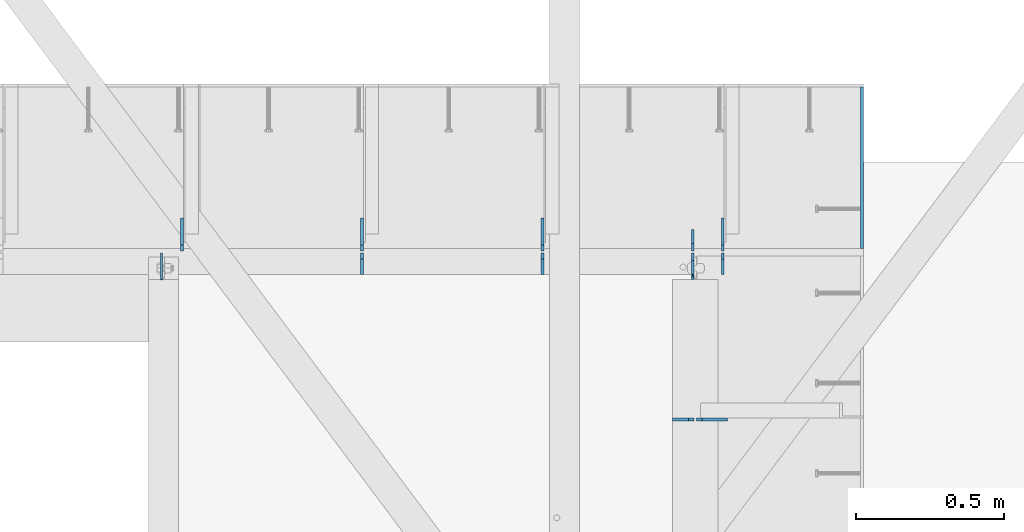
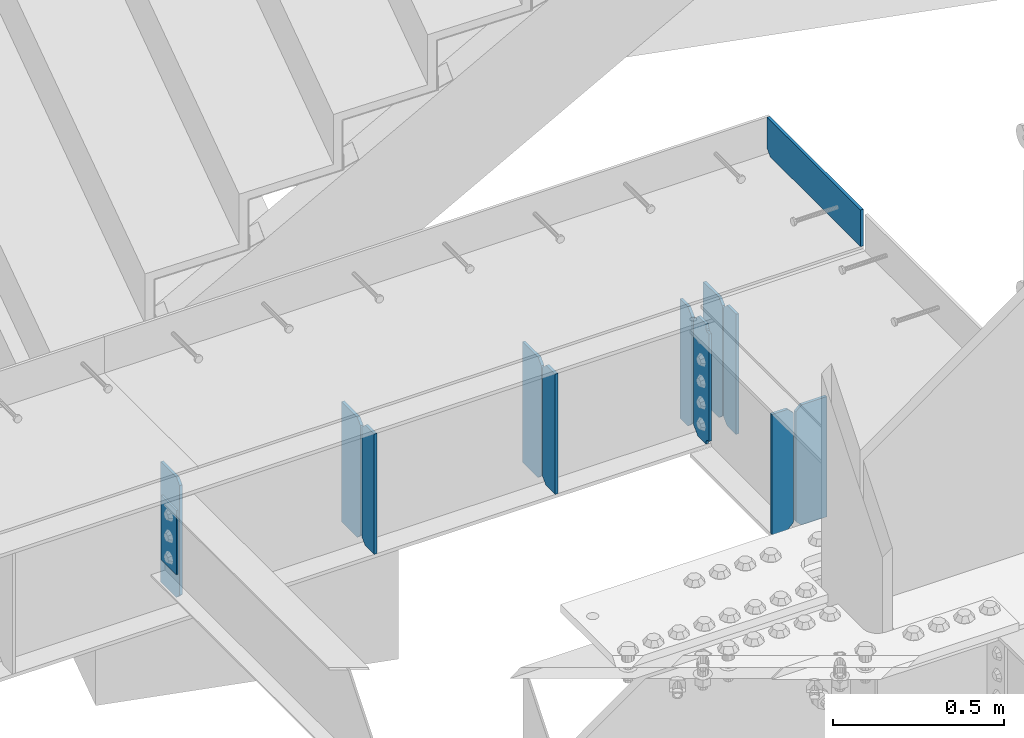
# One storey, part 1650 of 1763: 13 plates, 2 elements without a shape of their own.
"""IFC2X3 building model written with IfcOpenShell, lengths in millimetres."""

from ifc_helpers import new_model, si_unit, frame, origin_with_axes, place, context, subcontext, project, spatial, faceted_brep, material, type_object, element, aggregate, save


model = new_model("IFC2X3")

# Units and contexts
model_context = context("Model", 3, precision=1e-05, world=origin_with_axes())
body_context = subcontext(model_context, "Body", "Model", "MODEL_VIEW")
ifc_project = project(units=[si_unit("LENGTHUNIT", "METRE", prefix="MILLI"), si_unit("AREAUNIT", "SQUARE_METRE"), si_unit("VOLUMEUNIT", "CUBIC_METRE"), si_unit("MASSUNIT", "GRAM", prefix="KILO"), si_unit("TIMEUNIT", "SECOND"), si_unit("PLANEANGLEUNIT", "RADIAN"), si_unit("SOLIDANGLEUNIT", "STERADIAN"), si_unit("THERMODYNAMICTEMPERATUREUNIT", "DEGREE_CELSIUS"), si_unit("LUMINOUSINTENSITYUNIT", "LUMEN")], contexts=[model_context])

# Site, building, storey
site_placement = place(None, origin_with_axes())
site = spatial("IfcSite", under=ifc_project, at=site_placement, CompositionType="ELEMENT")
building_placement = place(site_placement, origin_with_axes())
building = spatial("IfcBuilding", under=site, at=building_placement, Name="Undefined", CompositionType="ELEMENT")
storey_placement = place(building_placement, origin_with_axes())
storey = spatial("IfcBuildingStorey", under=building, at=storey_placement, Name="Undefined", CompositionType="ELEMENT", Elevation=0.0)

# Assembly, plate
assembly_1_placement = place(storey_placement, origin_with_axes())
assembly_1 = element("IfcElementAssembly", 1, at=assembly_1_placement, inside=storey, Name="BEAM", AssemblyPlace="NOTDEFINED", PredefinedType="RIGID_FRAME")
ifc_material = material(Name="STEEL/A36")
plate_type_1 = type_object("IfcPlateType", PredefinedType="NOTDEFINED")
plate_1_placement = place(assembly_1_placement, frame((-34385.9151174483, 53657.5000095489, 5203.82498576935), z_axis=(-7.28999999410008e-07, 0.999999999970235, -7.68099774631993e-06), x_axis=(3.05799998314049e-06, 7.68099997558332e-06, 0.999999999965825)))
plate_1 = element("IfcPlate", 2, at=plate_1_placement, type_object=plate_type_1, material=ifc_material, Name="PLATE", context=body_context, shape_type="Brep", body=[
    faceted_brep([(0.0, -4.76249999999982, 0.0), (0.00404840682767826, -4.76249999999709, 527.049976349779), (0.00404840682494978, 4.76249999998254, 527.049976349794), (0.0, 4.76249999999982, 0.0), (19.054193971303, -4.76250000004075, 546.099832674743), (19.0541939713003, 4.76249999993161, 546.099832674765), (130.179183960079, -4.76250000030268, 546.098999024165), (130.179183960076, 4.76249999967695, 546.09899902418), (130.17500305171, -4.76250000028813, 3.63797880709171e-10), (130.175003051707, 4.7624999996915, 3.78349795937538e-10)], [[[0, 1, 2, 3]], [[1, 4, 5, 2]], [[4, 6, 7, 5]], [[6, 8, 9, 7]], [[8, 0, 3, 9]], [[5, 7, 9, 3, 2]], [[8, 6, 4, 1, 0]]]),
])

# Assembly, plates
assembly_2_placement = place(storey_placement, origin_with_axes())
assembly_2 = element("IfcElementAssembly", 3, at=assembly_2_placement, inside=storey, Name="BEAM", AssemblyPlace="NOTDEFINED", PredefinedType="RIGID_FRAME")
plate_type_2 = type_object("IfcPlateType", PredefinedType="NOTDEFINED")
plate_2_placement = place(assembly_2_placement, frame((-34841.0935236983, 53078.8562499995, 4752.975), z_axis=(0.0, 0.0, 1.0), x_axis=(-1.0, 0.0, 0.0)))
plate_2 = element("IfcPlate", 4, at=plate_2_placement, type_object=plate_type_2, material=ifc_material, Name="PLATE", context=body_context, shape_type="Brep", body=[
    faceted_brep([(0.0, -4.76249999999982, 0.0), (0.0, -4.76249999999709, 428.625), (0.0, 4.76249999999709, 428.625), (0.0, 4.76249999999982, 0.0), (85.7250022888184, -4.76249999999709, 428.625), (85.7250022888184, 4.76249999999709, 428.625), (104.775001525879, -4.76249999999709, 409.575000762939), (104.775001525879, 4.76249999999709, 409.575000762939), (104.775001525879, -4.76249999999709, 19.0499992370605), (104.775001525879, 4.76249999999709, 19.0499992370605), (85.7250022888184, -4.76249999999709, 0.0), (85.7250022888184, 4.76249999999709, 0.0)], [[[0, 1, 2, 3]], [[1, 4, 5, 2]], [[4, 6, 7, 5]], [[6, 8, 9, 7]], [[8, 10, 11, 9]], [[10, 0, 3, 11]], [[5, 7, 9, 11, 3, 2]], [[10, 8, 6, 4, 1, 0]]]),
])
plate_type_3 = type_object("IfcPlateType", PredefinedType="NOTDEFINED")
plate_3_placement = place(assembly_2_placement, frame((-34953.8060236984, 53078.8562499989, 4752.975), z_axis=(0.0, 0.0, 1.0), x_axis=(-1.0, 0.0, 0.0)))
plate_3 = element("IfcPlate", 5, at=plate_3_placement, type_object=plate_type_3, material=ifc_material, Name="PLATE", context=body_context, shape_type="Brep", body=[
    faceted_brep([(6.96272763889283e-08, -4.76249999999709, 19.0499992370605), (0.0, -4.76249999999709, 409.575000762939), (0.0, 4.76249999999709, 409.575000762939), (6.96454662829638e-08, 4.76249999999709, 19.0499992370605), (19.0499992370605, -4.76249999999709, 428.625), (19.0499992370605, 4.76249999999709, 428.625), (72.2312469482422, -4.76249999999709, 428.625), (72.2312469482422, 4.76249999999709, 428.625), (72.2312469482422, -4.76249999999709, 0.0), (72.2312469482422, 4.76249999999709, 0.0), (19.0499992370533, -4.76249999996799, -2.09183781407773e-11), (19.0499992370678, 4.76250000003347, -2.09183781407773e-11)], [[[0, 1, 2, 3]], [[1, 4, 5, 2]], [[4, 6, 7, 5]], [[6, 8, 9, 7]], [[8, 10, 11, 9]], [[10, 0, 3, 11]], [[5, 7, 9, 11, 3, 2]], [[10, 8, 6, 4, 1, 0]]]),
])
aggregate(assembly_2, [plate_2, plate_3])

# Plate
plate_4_placement = place(assembly_1_placement, frame((-34857.1669734054, 53568.6, 4752.975), z_axis=(0.0, 0.0, 1.0), x_axis=(0.0, 1.0, 0.0)))
plate_4 = element("IfcPlate", 6, at=plate_4_placement, type_object=plate_type_3, material=ifc_material, Name="PLATE", context=body_context, shape_type="Brep", body=[
    faceted_brep([(0.0, -4.76249999999982, 0.0), (0.0, -4.76249999999709, 428.625), (0.0, 4.76249999999709, 428.625), (0.0, 4.76249999999982, 0.0), (53.1812477111816, -4.76249999999709, 428.625), (53.1812477111816, 4.76249999999709, 428.625), (72.2312469482422, -4.76249999999709, 409.575000762939), (72.2312469482422, 4.76249999999709, 409.575000762939), (72.2312469482422, -4.76249999999709, 19.0499992370605), (72.2312469482422, 4.76249999999709, 19.0499992370605), (53.1812477111816, -4.76249999999709, 0.0), (53.1812477111816, 4.76249999999709, 0.0)], [[[0, 1, 2, 3]], [[1, 4, 5, 2]], [[4, 6, 7, 5]], [[6, 8, 9, 7]], [[8, 10, 11, 9]], [[10, 0, 3, 11]], [[5, 7, 9, 11, 3, 2]], [[10, 8, 6, 4, 1, 0]]]),
])

plate_5_placement = place(assembly_1_placement, frame((-35466.7669734054, 53568.6, 4752.975), z_axis=(0.0, 0.0, 1.0), x_axis=(0.0, 1.0, 0.0)))
plate_5 = element("IfcPlate", 7, at=plate_5_placement, type_object=plate_type_3, material=ifc_material, Name="PLATE", context=body_context, shape_type="Brep", body=[
    faceted_brep([(0.0, -4.76249999999982, 0.0), (0.0, -4.76249999999709, 428.625), (0.0, 4.76249999999709, 428.625), (0.0, 4.76249999999982, 0.0), (53.1812477111816, -4.76249999999709, 428.625), (53.1812477111816, 4.76249999999709, 428.625), (72.2312469482422, -4.76249999999709, 409.575000762939), (72.2312469482422, 4.76249999999709, 409.575000762939), (72.2312469482422, -4.76249999999709, 19.0499992370605), (72.2312469482422, 4.76249999999709, 19.0499992370605), (53.1812477111816, -4.76249999999709, 0.0), (53.1812477111816, 4.76249999999709, 0.0)], [[[0, 1, 2, 3]], [[1, 4, 5, 2]], [[4, 6, 7, 5]], [[6, 8, 9, 7]], [[8, 10, 11, 9]], [[10, 0, 3, 11]], [[5, 7, 9, 11, 3, 2]], [[10, 8, 6, 4, 1, 0]]]),
])

plate_6_placement = place(assembly_1_placement, frame((-36076.3669734054, 53568.6, 4752.975), z_axis=(0.0, 0.0, 1.0), x_axis=(0.0, 1.0, 0.0)))
plate_6 = element("IfcPlate", 8, at=plate_6_placement, type_object=plate_type_3, material=ifc_material, Name="PLATE", context=body_context, shape_type="Brep", body=[
    faceted_brep([(0.0, -4.76249999999982, 0.0), (0.0, -4.76249999999709, 428.625), (0.0, 4.76249999999709, 428.625), (0.0, 4.76249999999982, 0.0), (53.1812477111816, -4.76249999999709, 428.625), (53.1812477111816, 4.76249999999709, 428.625), (72.2312469482422, -4.76249999999709, 409.575000762939), (72.2312469482422, 4.76249999999709, 409.575000762939), (72.2312469482422, -4.76249999999709, 19.0499992370605), (72.2312469482422, 4.76249999999709, 19.0499992370605), (53.1812477111816, -4.76249999999709, 0.0), (53.1812477111816, 4.76249999999709, 0.0)], [[[0, 1, 2, 3]], [[1, 4, 5, 2]], [[4, 6, 7, 5]], [[6, 8, 9, 7]], [[8, 10, 11, 9]], [[10, 0, 3, 11]], [[5, 7, 9, 11, 3, 2]], [[10, 8, 6, 4, 1, 0]]]),
])

plate_7_placement = place(assembly_1_placement, frame((-34958.5690236144, 53648.76875, 4754.5625), z_axis=(0.0, 0.0, 1.0), x_axis=(0.0, 1.0, 0.0)))
plate_7 = element("IfcPlate", 9, at=plate_7_placement, type_object=plate_type_3, material=ifc_material, Name="PLATE", context=body_context, shape_type="Brep", body=[
    faceted_brep([(0.0, -4.76250000000073, 25.3999996185303), (0.0, -4.76249999999709, 400.050012588501), (0.0, 4.76249999999709, 400.050012588501), (0.0, 4.76250000000073, 25.3999996185303), (25.3999996185303, -4.76249999999709, 425.450012207031), (25.3999996185303, 4.76249999999709, 425.450012207031), (72.2312469482422, -4.76249999999709, 425.450012207031), (72.2312469482422, 4.76249999999709, 425.450012207031), (72.2312469482422, -4.76249999999709, 0.0), (72.2312469482422, 4.76249999999709, 0.0), (25.3999996185303, -4.76250000000073, 0.0), (25.3999996185303, 4.76250000000073, 0.0)], [[[0, 1, 2, 3]], [[1, 4, 5, 2]], [[4, 6, 7, 5]], [[6, 8, 9, 7]], [[8, 10, 11, 9]], [[10, 0, 3, 11]], [[5, 7, 9, 11, 3, 2]], [[10, 8, 6, 4, 1, 0]]]),
])

plate_type_4 = type_object("IfcPlateType", PredefinedType="NOTDEFINED")
plate_8_placement = place(assembly_1_placement, frame((-34857.1669734054, 53648.76875, 4752.975), z_axis=(0.0, 0.0, 1.0), x_axis=(0.0, 1.0, 0.0)))
plate_8 = element("IfcPlate", 10, at=plate_8_placement, type_object=plate_type_4, material=ifc_material, Name="PLATE", context=body_context, shape_type="Brep", body=[
    faceted_brep([(6.96272763889283e-08, -4.76249999999709, 19.0499992370605), (0.0, -4.76249999999709, 409.575000762939), (0.0, 4.76249999999709, 409.575000762939), (6.96454662829638e-08, 4.76249999999709, 19.0499992370605), (19.0499992370605, -4.76249999999709, 428.625), (19.0499992370605, 4.76249999999709, 428.625), (111.125, -4.76249999999709, 428.625), (111.125, 4.76249999999709, 428.625), (111.125, -4.76249999999709, 0.0), (111.125, 4.76249999999709, 0.0), (19.0499992370533, -4.76249999996799, -2.09183781407773e-11), (19.0499992370678, 4.76250000003347, -2.09183781407773e-11)], [[[0, 1, 2, 3]], [[1, 4, 5, 2]], [[4, 6, 7, 5]], [[6, 8, 9, 7]], [[8, 10, 11, 9]], [[10, 0, 3, 11]], [[5, 7, 9, 11, 3, 2]], [[10, 8, 6, 4, 1, 0]]]),
])

plate_9_placement = place(assembly_1_placement, frame((-35466.7669734054, 53648.76875, 4752.975), z_axis=(0.0, 0.0, 1.0), x_axis=(0.0, 1.0, 0.0)))
plate_9 = element("IfcPlate", 11, at=plate_9_placement, type_object=plate_type_4, material=ifc_material, Name="PLATE", context=body_context, shape_type="Brep", body=[
    faceted_brep([(6.96272763889283e-08, -4.76249999999709, 19.0499992370605), (0.0, -4.76249999999709, 409.575000762939), (0.0, 4.76249999999709, 409.575000762939), (6.96454662829638e-08, 4.76249999999709, 19.0499992370605), (19.0499992370605, -4.76249999999709, 428.625), (19.0499992370605, 4.76249999999709, 428.625), (111.125, -4.76249999999709, 428.625), (111.125, 4.76249999999709, 428.625), (111.125, -4.76249999999709, 0.0), (111.125, 4.76249999999709, 0.0), (19.0499992370533, -4.76249999996799, -2.09183781407773e-11), (19.0499992370678, 4.76250000003347, -2.09183781407773e-11)], [[[0, 1, 2, 3]], [[1, 4, 5, 2]], [[4, 6, 7, 5]], [[6, 8, 9, 7]], [[8, 10, 11, 9]], [[10, 0, 3, 11]], [[5, 7, 9, 11, 3, 2]], [[10, 8, 6, 4, 1, 0]]]),
])

plate_10_placement = place(assembly_1_placement, frame((-36076.3669734054, 53648.76875, 4752.975), z_axis=(0.0, 0.0, 1.0), x_axis=(0.0, 1.0, 0.0)))
plate_10 = element("IfcPlate", 12, at=plate_10_placement, type_object=plate_type_4, material=ifc_material, Name="PLATE", context=body_context, shape_type="Brep", body=[
    faceted_brep([(6.96272763889283e-08, -4.76249999999709, 19.0499992370605), (0.0, -4.76249999999709, 409.575000762939), (0.0, 4.76249999999709, 409.575000762939), (6.96454662829638e-08, 4.76249999999709, 19.0499992370605), (19.0499992370605, -4.76249999999709, 428.625), (19.0499992370605, 4.76249999999709, 428.625), (111.125, -4.76249999999709, 428.625), (111.125, 4.76249999999709, 428.625), (111.125, -4.76249999999709, 0.0), (111.125, 4.76249999999709, 0.0), (19.0499992370533, -4.76249999996799, -2.09183781407773e-11), (19.0499992370678, 4.76250000003347, -2.09183781407773e-11)], [[[0, 1, 2, 3]], [[1, 4, 5, 2]], [[4, 6, 7, 5]], [[6, 8, 9, 7]], [[8, 10, 11, 9]], [[10, 0, 3, 11]], [[5, 7, 9, 11, 3, 2]], [[10, 8, 6, 4, 1, 0]]]),
])

plate_11_placement = place(assembly_1_placement, frame((-36685.9669734054, 53648.76875, 4752.975), z_axis=(0.0, 0.0, 1.0), x_axis=(0.0, 1.0, 0.0)))
plate_11 = element("IfcPlate", 13, at=plate_11_placement, type_object=plate_type_4, material=ifc_material, Name="PLATE", context=body_context, shape_type="Brep", body=[
    faceted_brep([(6.96272763889283e-08, -4.76249999999709, 19.0499992370605), (0.0, -4.76249999999709, 409.575000762939), (0.0, 4.76249999999709, 409.575000762939), (6.96454662829638e-08, 4.76249999999709, 19.0499992370605), (19.0499992370605, -4.76249999999709, 428.625), (19.0499992370605, 4.76249999999709, 428.625), (111.125, -4.76249999999709, 428.625), (111.125, 4.76249999999709, 428.625), (111.125, -4.76249999999709, 0.0), (111.125, 4.76249999999709, 0.0), (19.0499992370533, -4.76249999996799, -2.09183781407773e-11), (19.0499992370678, 4.76250000003347, -2.09183781407773e-11)], [[[0, 1, 2, 3]], [[1, 4, 5, 2]], [[4, 6, 7, 5]], [[6, 8, 9, 7]], [[8, 10, 11, 9]], [[10, 0, 3, 11]], [[5, 7, 9, 11, 3, 2]], [[10, 8, 6, 4, 1, 0]]]),
])

plate_type_5 = type_object("IfcPlateType", PredefinedType="NOTDEFINED")
plate_12_placement = place(assembly_1_placement, frame((-34958.5690236144, 53640.83125, 4754.5625), z_axis=(0.0, 0.0, 1.0), x_axis=(0.0, -1.0, 0.0)))
plate_12 = element("IfcPlate", 14, at=plate_12_placement, type_object=plate_type_5, material=ifc_material, Name="PLATE", context=body_context, shape_type="Brep", body=[
    faceted_brep([(72.2312469482422, -4.76249999999709, 0.0), (72.2312469482422, 4.76249999999709, 0.0), (72.2312469482422, 4.76249999999709, 6.3499994277945), (72.2312469482422, -4.76249999999709, 6.3499994277945), (73.1979768708334, 4.76249999999709, 11.21007894584), (73.1979768708334, -4.76249999999709, 11.21007894584), (75.9509907713073, 4.76249999999709, 15.3302554139937), (75.9509907713073, -4.76249999999709, 15.3302554139937), (80.0711672394609, 4.76249999999709, 18.0832693144721), (80.0711672394609, -4.76249999999709, 18.0832693144721), (84.9312467575073, 4.76249999999709, 19.0499992370596), (84.9312467575073, -4.76249999999709, 19.0499992370596), (88.9000015258789, -4.76249999999709, 19.0499992370596), (88.9000015258789, 4.76249999999709, 19.0499992370596), (25.3999996185303, -4.76250000000073, 0.0), (0.0, -4.76250000000073, 25.3999996185303), (0.0, 4.76250000000073, 25.3999996185303), (25.3999996185303, 4.76250000000073, 0.0), (0.0, -4.76249999999709, 401.637506484985), (0.0, 4.76249999999709, 401.637506484985), (25.3999996185303, -4.76249999999709, 427.037506103516), (25.3999996185303, 4.76249999999709, 427.037506103516), (72.2312469482422, -4.76249999999709, 427.037506103516), (72.2312469482422, 4.76249999999709, 427.037506103516), (72.2312469482422, -4.76249999999709, 414.337499809265), (72.2312469482422, 4.76249999999709, 414.337499809265), (73.1979768708334, -4.76249999999709, 409.477420291219), (73.1979768708334, 4.76249999999709, 409.477420291219), (75.9509907713073, -4.76249999999709, 405.357243823066), (75.9509907713073, 4.76249999999709, 405.357243823066), (80.0711672394609, -4.76249999999709, 402.604229922587), (80.0711672394609, 4.76249999999709, 402.604229922587), (84.9312467575073, -4.76249999999709, 401.6375), (84.9312467575073, 4.76249999999709, 401.6375), (88.9000015258789, -4.76249999999709, 401.6375), (88.9000015258789, 4.76249999999709, 401.6375)], [[[0, 1, 2, 3]], [[3, 2, 4, 5]], [[5, 4, 6, 7]], [[7, 6, 8, 9]], [[9, 8, 10, 11]], [[12, 11, 10, 13]], [[14, 15, 16, 17]], [[15, 18, 19, 16]], [[18, 20, 21, 19]], [[21, 20, 22, 23]], [[22, 24, 25, 23]], [[26, 27, 25, 24]], [[28, 29, 27, 26]], [[30, 31, 29, 28]], [[32, 33, 31, 30]], [[34, 35, 33, 32]], [[35, 34, 12, 13]], [[8, 6, 4, 2, 1, 17, 16, 19, 21, 23, 25, 27, 29, 31, 33, 35, 13, 10]], [[0, 14, 17, 1]], [[34, 32, 30, 28, 26, 24, 22, 20, 18, 15, 14, 0, 3, 5, 7, 9, 11, 12]]]),
])

plate_type_6 = type_object("IfcPlateType", PredefinedType="NOTDEFINED")
plate_13_placement = place(assembly_1_placement, frame((-36754.758627365, 53640.83125, 5156.2), z_axis=(0.0, -1.0, 0.0), x_axis=(0.0, 0.0, -1.0)))
plate_13 = element("IfcPlate", 15, at=plate_13_placement, type_object=plate_type_6, material=ifc_material, Name="PLATE", context=body_context, shape_type="Brep", body=[
    faceted_brep([(1.81898940354586e-12, -3.17500000000291, 0.0), (0.0, -3.17499999999927, 88.9000015258789), (0.0, 3.17499999999927, 88.9000015258789), (-1.81898940354586e-12, 3.17499999997381, 0.0), (228.600006103516, -3.17499999999927, 88.9000015258789), (228.600006103516, 3.17499999999927, 88.9000015258789), (228.600006103516, -3.17500000001019, -7.27595761418343e-12), (228.600006103516, 3.17499999999563, -7.27595761418343e-12)], [[[0, 1, 2, 3]], [[1, 4, 5, 2]], [[4, 6, 7, 5]], [[6, 0, 3, 7]], [[5, 7, 3, 2]], [[6, 4, 1, 0]]]),
])

aggregate(assembly_1, [plate_1, plate_4, plate_8, plate_5, plate_9, plate_6, plate_10, plate_11, plate_13, plate_7, plate_12])

save(model, "model.ifc")
